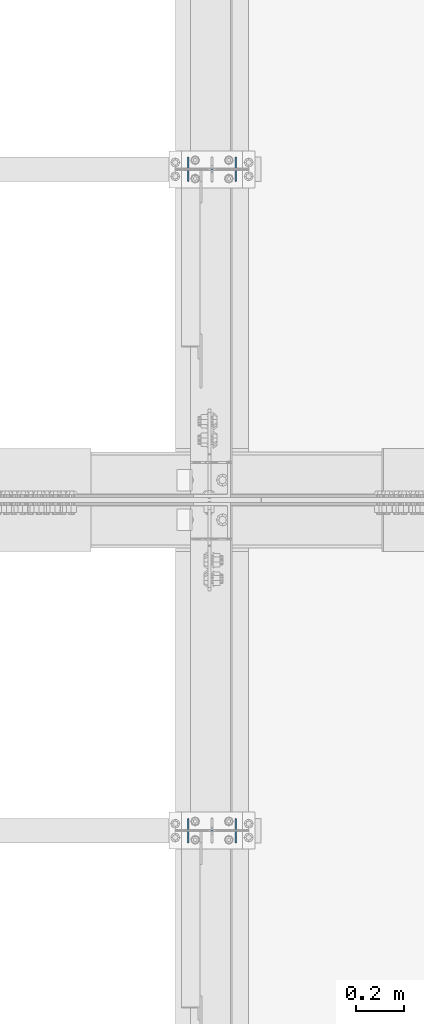
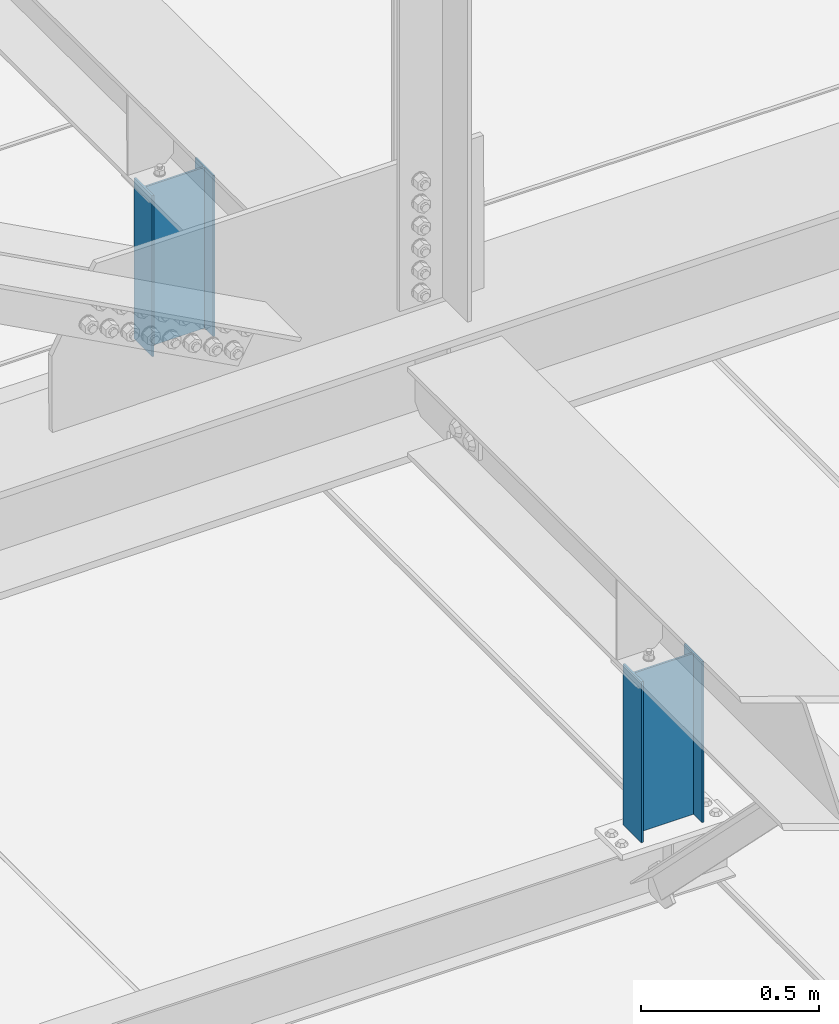
# One storey, part 1558 of 3843: 2 columns, 2 elements without a shape of their own.
"""IFC2X3 building model written with IfcOpenShell, lengths in millimetres."""

from ifc_helpers import new_model, si_unit, frame, origin_with_axes, place, context, subcontext, project, spatial, faceted_brep, material, type_object, element, aggregate, save


model = new_model("IFC2X3")

# Units and contexts
model_context = context("Model", 3, precision=1e-05, world=origin_with_axes())
body_context = subcontext(model_context, "Body", "Model", "MODEL_VIEW")
ifc_project = project(units=[si_unit("LENGTHUNIT", "METRE", prefix="MILLI"), si_unit("AREAUNIT", "SQUARE_METRE"), si_unit("VOLUMEUNIT", "CUBIC_METRE"), si_unit("MASSUNIT", "GRAM", prefix="KILO"), si_unit("TIMEUNIT", "SECOND"), si_unit("PLANEANGLEUNIT", "RADIAN"), si_unit("SOLIDANGLEUNIT", "STERADIAN"), si_unit("THERMODYNAMICTEMPERATUREUNIT", "DEGREE_CELSIUS"), si_unit("LUMINOUSINTENSITYUNIT", "LUMEN")], contexts=[model_context])

# Site, building, storey
site_placement = place(None, origin_with_axes())
site = spatial("IfcSite", under=ifc_project, at=site_placement, CompositionType="ELEMENT")
building_placement = place(site_placement, origin_with_axes())
building = spatial("IfcBuilding", under=site, at=building_placement, Name="Undefined", CompositionType="ELEMENT")
storey_placement = place(building_placement, origin_with_axes())
storey = spatial("IfcBuildingStorey", under=building, at=storey_placement, Name="Undefined", CompositionType="ELEMENT", Elevation=0.0)

# Assembly, column
assembly_1_placement = place(storey_placement, origin_with_axes())
assembly_1 = element("IfcElementAssembly", 1, at=assembly_1_placement, inside=storey, Name="POST", AssemblyPlace="NOTDEFINED", PredefinedType="RIGID_FRAME")
ifc_material = material(Name="STEEL/A992")
column_type = type_object("IfcColumnType", Name="W8X13", PredefinedType="NOTDEFINED")
column_1_placement = place(assembly_1_placement, frame((42062.4, 74256.9, 41503.6), z_axis=(-1.0, 0.0, 0.0), x_axis=(0.0, 0.0, 1.0)))
column_1 = element("IfcColumn", 2, at=column_1_placement, type_object=column_type, material=ifc_material, Name="POST", ObjectType="W8X13", context=body_context, shape_type="Brep", body=[
    faceted_brep([(19.0499994920028, 50.7999999999993, -101.600000000035), (19.0499995237551, 50.7999999999993, -95.2500000000364), (569.926122532481, 50.8000000000029, -95.2500000008076), (569.926122500729, 50.8000000000029, -101.600000000806), (19.0499995237551, 3.17499999999927, -95.2500000000364), (569.951670824536, 3.17500000000291, -95.2500000008076), (19.0500004762507, 3.17499999999927, 95.2499999999636), (569.951671777024, 3.17500000000291, 95.2499999991924), (19.0500004762507, 50.7999999999993, 95.2499999999636), (569.926123484969, 50.8000000000029, 95.2499999991924), (19.050000508003, 50.7999999999993, 101.599999999969), (569.926123516721, 50.8000000000029, 101.599999999191), (19.050000508003, -50.7999999999993, 101.599999999969), (569.980626539771, -50.8000000000029, 101.599999999198), (19.0500004762507, -50.7999999999993, 95.2499999999636), (569.980626508019, -50.8000000000029, 95.2499999991996), (19.0500004762507, -3.17499999999927, 95.2499999999636), (569.955078215964, -3.17500000000291, 95.2499999991924), (19.0499995237551, -3.17499999999927, -95.2500000000364), (569.955077263476, -3.17500000000291, -95.2500000008076), (19.0499995237551, -50.7999999999993, -95.2500000000364), (569.98062555553, -50.8000000000029, -95.2500000008004), (19.0499994920028, -50.7999999999993, -101.600000000035), (569.980625523778, -50.8000000000029, -101.600000000806)], [[[0, 1, 2, 3]], [[1, 4, 5, 2]], [[4, 6, 7, 5]], [[6, 8, 9, 7]], [[8, 10, 11, 9]], [[10, 12, 13, 11]], [[12, 14, 15, 13]], [[14, 16, 17, 15]], [[16, 18, 19, 17]], [[18, 20, 21, 19]], [[20, 22, 23, 21]], [[22, 0, 3, 23]], [[5, 7, 9, 11, 13, 15, 17, 19, 21, 23, 3, 2]], [[22, 20, 18, 16, 14, 12, 10, 8, 6, 4, 1, 0]]]),
])
aggregate(assembly_1, [column_1])

assembly_2_placement = place(storey_placement, origin_with_axes())
assembly_2 = element("IfcElementAssembly", 3, at=assembly_2_placement, inside=storey, Name="POST", AssemblyPlace="NOTDEFINED", PredefinedType="RIGID_FRAME")
column_2_placement = place(assembly_2_placement, frame((42062.4, 77000.1, 41503.6), z_axis=(-1.0, 0.0, 0.0), x_axis=(0.0, 0.0, 1.0)))
column_2 = element("IfcColumn", 4, at=column_2_placement, type_object=column_type, material=ifc_material, Name="POST", ObjectType="W8X13", context=body_context, shape_type="Brep", body=[
    faceted_brep([(19.0499994920028, 50.7999999999993, -101.600000000035), (19.0499995237551, 50.7999999999993, -95.2500000000364), (569.912499523743, 50.8000000000029, -95.2500000008076), (569.912499491991, 50.8000000000029, -101.600000000806), (19.0499995237551, 3.17499999999927, -95.2500000000364), (569.912499523743, 3.17500000000291, -95.2500000008076), (19.0500004762507, 3.17499999999927, 95.2499999999636), (569.912500476239, 3.17500000000291, 95.2499999991924), (19.0500004762507, 50.7999999999993, 95.2499999999636), (569.912500476239, 50.8000000000029, 95.2499999991924), (19.050000508003, 50.7999999999993, 101.599999999969), (569.912500507991, 50.8000000000029, 101.599999999191), (19.050000508003, -50.7999999999993, 101.599999999969), (569.912500507991, -50.8000000000029, 101.599999999191), (19.0500004762507, -50.7999999999993, 95.2499999999636), (569.912500476239, -50.8000000000029, 95.2499999991924), (19.0500004762507, -3.17499999999927, 95.2499999999636), (569.912500476239, -3.17500000000291, 95.2499999991924), (19.0499995237551, -3.17499999999927, -95.2500000000364), (569.912499523743, -3.17500000000291, -95.2500000008076), (19.0499995237551, -50.7999999999993, -95.2500000000364), (569.912499523743, -50.8000000000029, -95.2500000008076), (19.0499994920028, -50.7999999999993, -101.600000000035), (569.912499491991, -50.8000000000029, -101.600000000806)], [[[0, 1, 2, 3]], [[1, 4, 5, 2]], [[4, 6, 7, 5]], [[6, 8, 9, 7]], [[8, 10, 11, 9]], [[10, 12, 13, 11]], [[12, 14, 15, 13]], [[14, 16, 17, 15]], [[16, 18, 19, 17]], [[18, 20, 21, 19]], [[20, 22, 23, 21]], [[22, 0, 3, 23]], [[5, 7, 9, 11, 13, 15, 17, 19, 21, 23, 3, 2]], [[22, 20, 18, 16, 14, 12, 10, 8, 6, 4, 1, 0]]]),
])
aggregate(assembly_2, [column_2])

save(model, "model.ifc")
